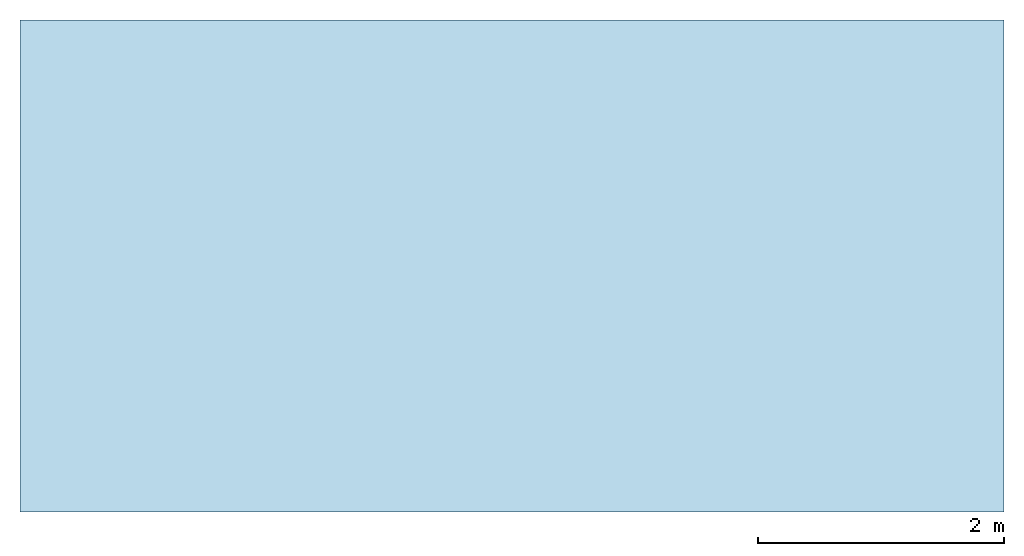
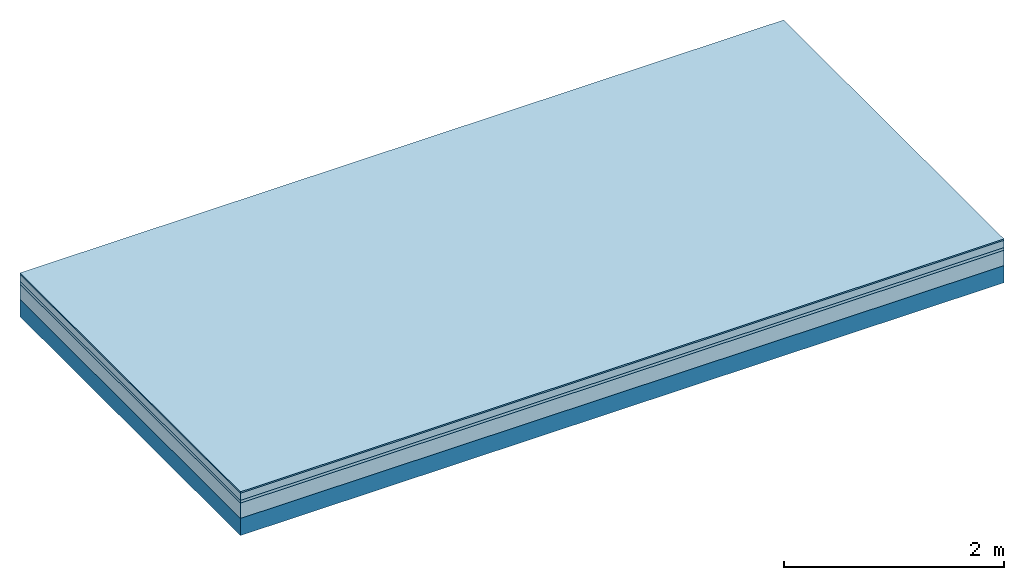
# One storey: 4 plates, 1 member, 1 element without a shape of its own.
"""IFC4 building model written with IfcOpenShell, lengths in metres."""

from ifc_helpers import new_model, si_unit, derived_unit, direction, frame, frame_2d, origin, origin_with_axes, place, context, project, spatial, rectangle, extrude, material, layer, layer_set, type_object, element, aggregate, save


model = new_model("IFC4")

# Units and contexts
plan_context = context("Plan", 3, precision=1e-05, world=origin(), true_north=direction((0.0, 1.0)))
model_context = context("Model", 3, precision=1e-05, world=origin(), true_north=direction((0.0, 1.0)))
ifc_project = project(units=[si_unit("LENGTHUNIT", "METRE"), derived_unit("SOUNDPRESSUREUNIT", [(si_unit("PRESSUREUNIT", "PASCAL", prefix="MICRO"), 0)]), si_unit("ENERGYUNIT", "JOULE", prefix="MEGA"), si_unit("MASSUNIT", "GRAM", prefix="KILO"), derived_unit("THERMALTRANSMITTANCEUNIT", [(si_unit("POWERUNIT", "WATT"), 1), (si_unit("AREAUNIT", "SQUARE_METRE"), -1), (si_unit("THERMODYNAMICTEMPERATUREUNIT", "KELVIN"), -1)]), derived_unit("AREADENSITYUNIT", [(si_unit("MASSUNIT", "GRAM", prefix="KILO"), 1), (si_unit("AREAUNIT", "SQUARE_METRE"), -1)]), derived_unit("USERDEFINED", [(si_unit("ENERGYUNIT", "JOULE", prefix="MEGA"), 1), (si_unit("AREAUNIT", "SQUARE_METRE"), -1)])], contexts=[plan_context, model_context])

# Site, building, storey
site = spatial("IfcSite", under=ifc_project)
building_placement = place(None, origin())
building = spatial("IfcBuilding", under=site, at=building_placement)
storey_placement = place(building_placement, origin())
storey = spatial("IfcBuildingStorey", under=building, at=storey_placement)

# Slab, member, plates
ifc_material_1 = material(Category="11.013")
ifc_layer_1 = layer(ifc_material_1, 0.015, Name="Flooring")
ifc_material_2 = material(Name="Cement screed", Category="04.006")
ifc_layer_2 = layer(ifc_material_2, 0.08, Name="On-material")
ifc_material_3 = material(Name="Wood fiber generic product", Category="10.009")
ifc_layer_3 = layer(ifc_material_3, 0.03, Name="Impact sound insulation")
ifc_material_4 = material(Category="01.002")
ifc_layer_4 = layer(ifc_material_4, 0.17, Name="Sub-floor")
ifc_material_5 = material(Name="Rigid, of the art")
ifc_layer_5 = layer(ifc_material_5, 0.0, Name="Bond")
ifc_layer_6 = layer(None, 0.19, Name="Supporting structure")
ifc_layer_set = layer_set([ifc_layer_1, ifc_layer_2, ifc_layer_3, ifc_layer_4, ifc_layer_5, ifc_layer_6])
slab_type = type_object("IfcSlabType", Name="A2195", PredefinedType="NOTDEFINED", material=ifc_layer_set)
slab_placement = place(None, frame((0.0, 0.0, 0.0), z_axis=(0.0, 0.0, -1.0), x_axis=(1.0, 0.0, 0.0)))
slab = element("IfcSlab", 1, at=slab_placement, inside=storey, type_object=slab_type, material=ifc_layer_set, Name="Slab #1")
ifc_material_6 = material(Name="Solid timber panel")
member_placement = place(slab_placement, origin())
member = element("IfcMember", 2, at=member_placement, material=ifc_material_6, Name="Supporting structure", context=plan_context, shape_type="SweptSolid", body=[
    extrude(rectangle(XDim=1.0, YDim=0.19, at=frame_2d((0.5, 0.095), x_axis=(1.0, 0.0))), frame((0.0, 4.0, 0.295), z_axis=(0.0, -1.0, 0.0), x_axis=(1.0, 0.0, 0.0)), (0.0, 0.0, 1.0), 4.0),
    extrude(rectangle(XDim=1.0, YDim=0.19, at=frame_2d((0.5, 0.095), x_axis=(1.0, 0.0))), frame((1.0, 4.0, 0.295), z_axis=(0.0, -1.0, 0.0), x_axis=(1.0, 0.0, 0.0)), (0.0, 0.0, 1.0), 4.0),
    extrude(rectangle(XDim=1.0, YDim=0.19, at=frame_2d((0.5, 0.095), x_axis=(1.0, 0.0))), frame((2.0, 4.0, 0.295), z_axis=(0.0, -1.0, 0.0), x_axis=(1.0, 0.0, 0.0)), (0.0, 0.0, 1.0), 4.0),
    extrude(rectangle(XDim=1.0, YDim=0.19, at=frame_2d((0.5, 0.095), x_axis=(1.0, 0.0))), frame((3.0, 4.0, 0.295), z_axis=(0.0, -1.0, 0.0), x_axis=(1.0, 0.0, 0.0)), (0.0, 0.0, 1.0), 4.0),
    extrude(rectangle(XDim=1.0, YDim=0.19, at=frame_2d((0.5, 0.095), x_axis=(1.0, 0.0))), frame((4.0, 4.0, 0.295), z_axis=(0.0, -1.0, 0.0), x_axis=(1.0, 0.0, 0.0)), (0.0, 0.0, 1.0), 4.0),
    extrude(rectangle(XDim=1.0, YDim=0.19, at=frame_2d((0.5, 0.095), x_axis=(1.0, 0.0))), frame((5.0, 4.0, 0.295), z_axis=(0.0, -1.0, 0.0), x_axis=(1.0, 0.0, 0.0)), (0.0, 0.0, 1.0), 4.0),
    extrude(rectangle(XDim=1.0, YDim=0.19, at=frame_2d((0.5, 0.095), x_axis=(1.0, 0.0))), frame((6.0, 4.0, 0.295), z_axis=(0.0, -1.0, 0.0), x_axis=(1.0, 0.0, 0.0)), (0.0, 0.0, 1.0), 4.0),
    extrude(rectangle(XDim=1.0, YDim=0.19, at=frame_2d((0.5, 0.095), x_axis=(1.0, 0.0))), frame((7.0, 4.0, 0.295), z_axis=(0.0, -1.0, 0.0), x_axis=(1.0, 0.0, 0.0)), (0.0, 0.0, 1.0), 4.0),
])
plate_1_placement = place(slab_placement, origin())
plate_1 = element("IfcPlate", 3, at=plate_1_placement, material=ifc_material_1, Name="Flooring", context=plan_context, shape_type="SweptSolid", body=[
    extrude(rectangle(XDim=8.0, YDim=4.0, at=frame_2d((4.0, 2.0), x_axis=(1.0, 0.0))), origin_with_axes(), (0.0, 0.0, 1.0), 0.015),
])
plate_2_placement = place(slab_placement, origin())
plate_2 = element("IfcPlate", 4, at=plate_2_placement, material=ifc_material_2, Name="On-material", context=plan_context, shape_type="SweptSolid", body=[
    extrude(rectangle(XDim=8.0, YDim=4.0, at=frame_2d((4.0, 2.0), x_axis=(1.0, 0.0))), frame((0.0, 0.0, 0.015), z_axis=(0.0, 0.0, 1.0), x_axis=(1.0, 0.0, 0.0)), (0.0, 0.0, 1.0), 0.08),
])
plate_3_placement = place(slab_placement, origin())
plate_3 = element("IfcPlate", 5, at=plate_3_placement, material=ifc_material_3, Name="Impact sound insulation", context=plan_context, shape_type="SweptSolid", body=[
    extrude(rectangle(XDim=8.0, YDim=4.0, at=frame_2d((4.0, 2.0), x_axis=(1.0, 0.0))), frame((0.0, 0.0, 0.095), z_axis=(0.0, 0.0, 1.0), x_axis=(1.0, 0.0, 0.0)), (0.0, 0.0, 1.0), 0.03),
])
plate_4_placement = place(slab_placement, origin())
plate_4 = element("IfcPlate", 6, at=plate_4_placement, material=ifc_material_4, Name="Sub-floor", context=plan_context, shape_type="SweptSolid", body=[
    extrude(rectangle(XDim=8.0, YDim=4.0, at=frame_2d((4.0, 2.0), x_axis=(1.0, 0.0))), frame((0.0, 0.0, 0.125), z_axis=(0.0, 0.0, 1.0), x_axis=(1.0, 0.0, 0.0)), (0.0, 0.0, 1.0), 0.17),
])
aggregate(slab, [plate_1, plate_2, plate_3, plate_4, member])

save(model, "model.ifc")
